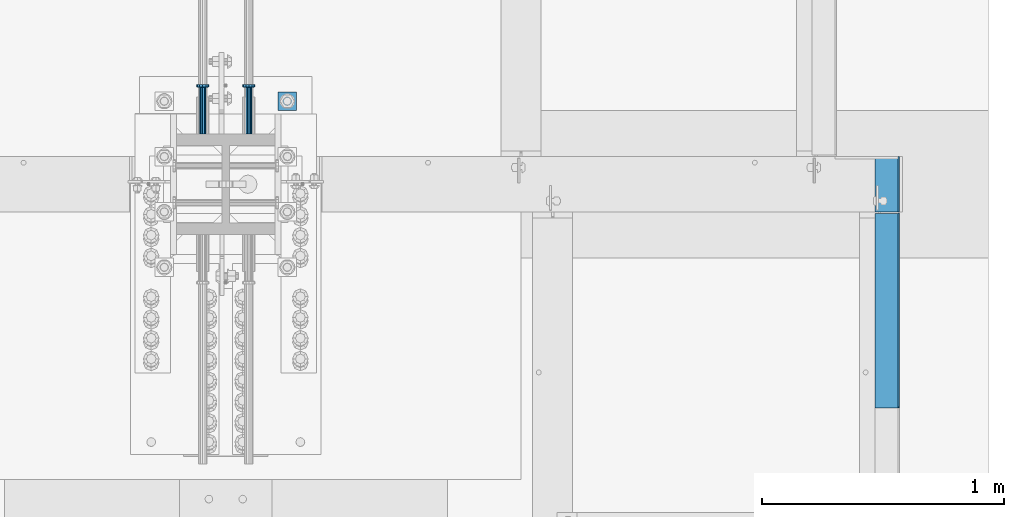
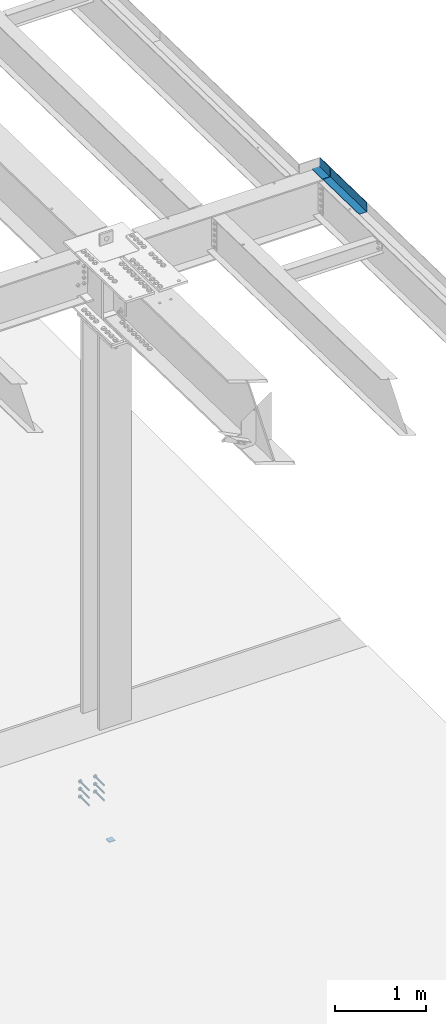
# One storey, part 1324 of 1763: 9 beams, 4 elements without a shape of their own.
"""IFC2X3 building model written with IfcOpenShell, lengths in millimetres."""

from ifc_helpers import new_model, si_unit, frame, origin_with_axes, place, context, subcontext, project, spatial, faceted_brep, material, type_object, element, aggregate, save


model = new_model("IFC2X3")

# Units and contexts
model_context = context("Model", 3, precision=1e-05, world=origin_with_axes())
body_context = subcontext(model_context, "Body", "Model", "MODEL_VIEW")
ifc_project = project(units=[si_unit("LENGTHUNIT", "METRE", prefix="MILLI"), si_unit("AREAUNIT", "SQUARE_METRE"), si_unit("VOLUMEUNIT", "CUBIC_METRE"), si_unit("MASSUNIT", "GRAM", prefix="KILO"), si_unit("TIMEUNIT", "SECOND"), si_unit("PLANEANGLEUNIT", "RADIAN"), si_unit("SOLIDANGLEUNIT", "STERADIAN"), si_unit("THERMODYNAMICTEMPERATUREUNIT", "DEGREE_CELSIUS"), si_unit("LUMINOUSINTENSITYUNIT", "LUMEN")], contexts=[model_context])

# Site, building, storey
site_placement = place(None, origin_with_axes())
site = spatial("IfcSite", under=ifc_project, at=site_placement, CompositionType="ELEMENT")
building_placement = place(site_placement, origin_with_axes())
building = spatial("IfcBuilding", under=site, at=building_placement, Name="Undefined", CompositionType="ELEMENT")
storey_placement = place(building_placement, origin_with_axes())
storey = spatial("IfcBuildingStorey", under=building, at=storey_placement, Name="Undefined", CompositionType="ELEMENT", Elevation=0.0)

# Assembly, beam
assembly_1_placement = place(storey_placement, origin_with_axes())
assembly_1 = element("IfcElementAssembly", 1, at=assembly_1_placement, inside=storey, Name="BEAM", AssemblyPlace="NOTDEFINED", PredefinedType="RIGID_FRAME")
ifc_material_1 = material(Name="STEEL/A36")
beam_type_1 = type_object("IfcBeamType", PredefinedType="NOTDEFINED")
beam_1_placement = place(assembly_1_placement, frame((-21348.1419611974, 13690.599999996, 11634.9147294638), z_axis=(0.0, -1.0, 0.0), x_axis=(1.0, 0.0, 0.0)))
beam_1 = element("IfcBeam", 2, at=beam_1_placement, type_object=beam_type_1, material=ifc_material_1, Name="BENT_PLATE", context=body_context, shape_type="Brep", body=[
    faceted_brep([(0.0, -3.17499999999927, -114.300000000003), (0.0, -3.17499999999927, 114.300000000003), (0.0, 3.17499999999927, 114.300000000003), (0.0, 3.17499999999927, -114.300000000003), (95.2499984741225, 3.17499999999927, 114.299999999999), (95.2499984741225, 3.17499999999927, -114.299999999999), (101.599998474121, -3.17499999999927, -114.299999999999), (101.599998474121, -3.17499999999927, 114.299999999999), (95.2499984741225, 123.825000000001, 114.299999999999), (95.2499984741225, 123.825000000001, -114.299999999999), (101.599998474121, 123.825000000001, 114.299999999999), (101.599998474121, 123.825000000001, -114.299999999999)], [[[0, 1, 2, 3]], [[3, 2, 4, 5]], [[1, 0, 6, 7]], [[5, 4, 8, 9]], [[4, 2, 1, 7, 10, 8]], [[7, 6, 11, 10]], [[6, 0, 3, 5, 9, 11]], [[10, 11, 9, 8]]]),
])
aggregate(assembly_1, [beam_1])

assembly_2_placement = place(storey_placement, origin_with_axes())
assembly_2 = element("IfcElementAssembly", 3, at=assembly_2_placement, inside=storey, Name="BEAM", AssemblyPlace="NOTDEFINED", PredefinedType="RIGID_FRAME")
beam_2_placement = place(assembly_2_placement, frame((-21348.1372736983, 13168.1616586829, 11645.8374789734), z_axis=(0.0, -0.999781542838788, 0.0209013539966307), x_axis=(1.0, 0.0, 0.0)))
beam_2 = element("IfcBeam", 4, at=beam_2_placement, type_object=beam_type_1, material=ifc_material_1, Name="BENT_PLATE", context=body_context, shape_type="Brep", body=[
    faceted_brep([(3.63797880709171e-12, -3.17500000013388, -401.010500000322), (-3.63797880709171e-12, -3.17499999986831, 401.010500000324), (-3.63797880709171e-12, 3.17500000013752, 401.01050000032), (3.63797880709171e-12, 3.17499999987194, -401.010500000324), (95.2499984741116, 3.17500000011933, 401.01050000032), (95.2499984741262, 3.17499999985557, -401.010500000322), (101.599998474125, -3.17500000015207, -401.01050000032), (101.59999847411, -3.1749999998865, 401.010500000324), (95.2499984741189, 123.825003583939, 401.010500000282), (95.2499984741189, 123.825003583685, -401.010500000362), (101.599998474117, 123.825003583939, 401.010500000282), (101.599998474117, 123.825003583685, -401.010500000362)], [[[0, 1, 2, 3]], [[3, 2, 4, 5]], [[1, 0, 6, 7]], [[5, 4, 8, 9]], [[4, 2, 1, 7, 10, 8]], [[7, 6, 11, 10]], [[6, 0, 3, 5, 9, 11]], [[10, 11, 9, 8]]]),
])
aggregate(assembly_2, [beam_2])

assembly_3_placement = place(storey_placement, origin_with_axes())
assembly_3 = element("IfcElementAssembly", 5, at=assembly_3_placement, inside=storey, Name="TEMPLATE", AssemblyPlace="NOTDEFINED", PredefinedType="RIGID_FRAME")
beam_type_2 = type_object("IfcBeamType", PredefinedType="NOTDEFINED")
beam_3_placement = place(assembly_3_placement, frame((-23773.8372736984, 13995.3999999999, 3348.0375), z_axis=(1.0, 0.0, 0.0), x_axis=(0.0, 1.0, 0.0)))
beam_3 = element("IfcBeam", 6, at=beam_3_placement, type_object=beam_type_2, material=ifc_material_1, Name="WASHER PLATE", context=body_context, shape_type="Brep", body=[
    faceted_brep([(0.0, 4.76249999999709, -38.1000000000004), (0.0, 4.76249999999709, 38.1000000000004), (76.2000000000007, 4.76249999999982, 38.0999999999985), (76.2000000000007, 4.76249999999982, -38.0999999999985), (0.0, -4.76249999999709, 38.1000000000004), (76.2000000000007, -4.76249999999982, 38.0999999999985), (0.0, -4.76249999999709, -38.1000000000004), (76.2000000000007, -4.76249999999982, -38.0999999999985)], [[[0, 1, 2, 3]], [[1, 4, 5, 2]], [[4, 6, 7, 5]], [[6, 0, 3, 7]], [[5, 7, 3, 2]], [[6, 4, 1, 0]]]),
])
aggregate(assembly_3, [beam_3])

# Assembly, beams
assembly_4_placement = place(storey_placement, origin_with_axes())
assembly_4 = element("IfcElementAssembly", 7, at=assembly_4_placement, inside=storey, Name="COLUMN", AssemblyPlace="NOTDEFINED", PredefinedType="RIGID_FRAME")
ifc_material_2 = material(Name="STEEL/A108")
beam_type_3 = type_object("IfcBeamType", PredefinedType="NOTDEFINED")
beam_4_placement = place(assembly_4_placement, frame((-23932.5872736985, 13898.5624312644, 4216.40000000002), z_axis=(1.0, 0.0, 0.0), x_axis=(0.0, 1.0, 0.0)))
beam_4 = element("IfcBeam", 8, at=beam_4_placement, type_object=beam_type_3, material=ifc_material_2, Name="HEADED STUD ANCHOR", context=body_context, shape_type="Brep", body=[
    faceted_brep([(0.0, -12.6999999999971, -1.81898940354586e-12), (3.63797880709171e-12, -11.0, -6.34999990463257), (191.00799999576, -11.0, -6.34999990454889), (191.007999995752, -12.6999998092651, 8.36735125631094e-11), (7.27595761418343e-12, -6.34999990463257, -11.0), (191.00799999576, -6.34999990463257, -10.9999999999163), (3.63797880709171e-12, 0.0, -12.6999998092651), (191.00799999576, 0.0, -12.6999998091815), (7.27595761418343e-12, 6.34999990463257, -11.0), (191.00799999576, 6.34999990463257, -10.9999999999163), (3.63797880709171e-12, 11.0, -6.34999990463257), (191.00799999576, 11.0, -6.34999990454889), (0.0, 12.6999999999971, -1.81898940354586e-12), (191.007999995752, 12.6999998092651, 8.36735125631094e-11), (0.0, 11.0, 6.34999990463257), (191.007999995752, 11.0, 6.34999990471624), (-3.63797880709171e-12, 6.34999990463257, 11.0), (191.007999995749, 6.34999990463257, 11.0000000000837), (-3.63797880709171e-12, 0.0, 12.6999998092651), (191.007999995749, 0.0, 12.6999998093488), (-3.63797880709171e-12, -6.34999990463257, 11.0), (191.007999995749, -6.34999990463257, 11.0000000000837), (0.0, -11.0, 6.34999990463257), (191.007999995752, -11.0, 6.34999990471624), (193.039999995715, -22.0, -12.6999998091796), (193.039999995708, -25.3999996185303, 8.54925019666553e-11), (193.039999995719, -12.6999998092651, -21.9999999999145), (193.039999995719, 0.0, -25.3999996184448), (193.039999995719, 12.6999998092651, -21.9999999999145), (193.039999995715, 22.0, -12.6999998091796), (193.039999995708, 25.3999996185303, 8.54925019666553e-11), (193.039999995704, 22.0, 12.6999998093506), (193.039999995701, 12.6999998092651, 22.0000000000855), (193.039999995697, 0.0, 25.3999996186158), (193.039999995701, -12.6999998092651, 22.0000000000855), (193.039999995704, -22.0, 12.6999998093506), (203.199999995486, -22.0, -12.6999998091742), (203.199999995482, -25.3999996185303, 9.09494701772928e-11), (203.199999995493, -12.6999998092651, -21.9999999999091), (203.199999995493, 0.0, -25.3999996184393), (203.199999995493, 12.6999998092651, -21.9999999999091), (203.199999995486, 22.0, -12.6999998091742), (203.199999995482, 25.3999996185303, 9.09494701772928e-11), (203.199999995479, 22.0, 12.6999998093561), (203.199999995475, 12.6999998092651, 22.0000000000909), (203.199999995471, 0.0, 25.3999996186212), (203.199999995475, -12.6999998092651, 22.0000000000909), (203.199999995479, -22.0, 12.6999998093561)], [[[0, 1, 2, 3]], [[1, 4, 5, 2]], [[4, 6, 7, 5]], [[6, 8, 9, 7]], [[8, 10, 11, 9]], [[10, 12, 13, 11]], [[12, 14, 15, 13]], [[14, 16, 17, 15]], [[16, 18, 19, 17]], [[18, 20, 21, 19]], [[20, 22, 23, 21]], [[22, 0, 3, 23]], [[22, 20, 18, 16, 14, 12, 10, 8, 6, 4, 1, 0]], [[3, 2, 24, 25]], [[2, 5, 26, 24]], [[5, 7, 27, 26]], [[7, 9, 28, 27]], [[9, 11, 29, 28]], [[11, 13, 30, 29]], [[13, 15, 31, 30]], [[15, 17, 32, 31]], [[17, 19, 33, 32]], [[19, 21, 34, 33]], [[21, 23, 35, 34]], [[23, 3, 25, 35]], [[25, 24, 36, 37]], [[24, 26, 38, 36]], [[26, 27, 39, 38]], [[27, 28, 40, 39]], [[28, 29, 41, 40]], [[29, 30, 42, 41]], [[30, 31, 43, 42]], [[31, 32, 44, 43]], [[32, 33, 45, 44]], [[33, 34, 46, 45]], [[34, 35, 47, 46]], [[35, 25, 37, 47]], [[38, 39, 40, 41, 42, 43, 44, 45, 46, 47, 37, 36]]]),
])
beam_5_placement = place(assembly_4_placement, frame((-23932.5872736985, 13898.5624312644, 4114.80000000002), z_axis=(1.0, 0.0, 0.0), x_axis=(0.0, 1.0, 0.0)))
beam_5 = element("IfcBeam", 9, at=beam_5_placement, type_object=beam_type_3, material=ifc_material_2, Name="HEADED STUD ANCHOR", context=body_context, shape_type="Brep", body=[
    faceted_brep([(0.0, -12.6999999999971, -1.81898940354586e-12), (3.63797880709171e-12, -11.0, -6.34999990463257), (191.00799999576, -11.0, -6.34999990454889), (191.007999995752, -12.6999998092651, 8.36735125631094e-11), (7.27595761418343e-12, -6.34999990463257, -11.0), (191.00799999576, -6.34999990463257, -10.9999999999163), (3.63797880709171e-12, 0.0, -12.6999998092651), (191.00799999576, 0.0, -12.6999998091815), (7.27595761418343e-12, 6.34999990463257, -11.0), (191.00799999576, 6.34999990463257, -10.9999999999163), (3.63797880709171e-12, 11.0, -6.34999990463257), (191.00799999576, 11.0, -6.34999990454889), (0.0, 12.6999999999971, -1.81898940354586e-12), (191.007999995752, 12.6999998092651, 8.36735125631094e-11), (0.0, 11.0, 6.34999990463257), (191.007999995752, 11.0, 6.34999990471624), (-3.63797880709171e-12, 6.34999990463257, 11.0), (191.007999995749, 6.34999990463257, 11.0000000000837), (-3.63797880709171e-12, 0.0, 12.6999998092651), (191.007999995749, 0.0, 12.6999998093488), (-3.63797880709171e-12, -6.34999990463257, 11.0), (191.007999995749, -6.34999990463257, 11.0000000000837), (0.0, -11.0, 6.34999990463257), (191.007999995752, -11.0, 6.34999990471624), (193.039999995715, -22.0, -12.6999998091796), (193.039999995708, -25.3999996185303, 8.54925019666553e-11), (193.039999995719, -12.6999998092651, -21.9999999999145), (193.039999995719, 0.0, -25.3999996184448), (193.039999995719, 12.6999998092651, -21.9999999999145), (193.039999995715, 22.0, -12.6999998091796), (193.039999995708, 25.3999996185303, 8.54925019666553e-11), (193.039999995704, 22.0, 12.6999998093506), (193.039999995701, 12.6999998092651, 22.0000000000855), (193.039999995697, 0.0, 25.3999996186158), (193.039999995701, -12.6999998092651, 22.0000000000855), (193.039999995704, -22.0, 12.6999998093506), (203.199999995486, -22.0, -12.6999998091742), (203.199999995482, -25.3999996185303, 9.09494701772928e-11), (203.199999995493, -12.6999998092651, -21.9999999999091), (203.199999995493, 0.0, -25.3999996184393), (203.199999995493, 12.6999998092651, -21.9999999999091), (203.199999995486, 22.0, -12.6999998091742), (203.199999995482, 25.3999996185303, 9.09494701772928e-11), (203.199999995479, 22.0, 12.6999998093561), (203.199999995475, 12.6999998092651, 22.0000000000909), (203.199999995471, 0.0, 25.3999996186212), (203.199999995475, -12.6999998092651, 22.0000000000909), (203.199999995479, -22.0, 12.6999998093561)], [[[0, 1, 2, 3]], [[1, 4, 5, 2]], [[4, 6, 7, 5]], [[6, 8, 9, 7]], [[8, 10, 11, 9]], [[10, 12, 13, 11]], [[12, 14, 15, 13]], [[14, 16, 17, 15]], [[16, 18, 19, 17]], [[18, 20, 21, 19]], [[20, 22, 23, 21]], [[22, 0, 3, 23]], [[22, 20, 18, 16, 14, 12, 10, 8, 6, 4, 1, 0]], [[3, 2, 24, 25]], [[2, 5, 26, 24]], [[5, 7, 27, 26]], [[7, 9, 28, 27]], [[9, 11, 29, 28]], [[11, 13, 30, 29]], [[13, 15, 31, 30]], [[15, 17, 32, 31]], [[17, 19, 33, 32]], [[19, 21, 34, 33]], [[21, 23, 35, 34]], [[23, 3, 25, 35]], [[25, 24, 36, 37]], [[24, 26, 38, 36]], [[26, 27, 39, 38]], [[27, 28, 40, 39]], [[28, 29, 41, 40]], [[29, 30, 42, 41]], [[30, 31, 43, 42]], [[31, 32, 44, 43]], [[32, 33, 45, 44]], [[33, 34, 46, 45]], [[34, 35, 47, 46]], [[35, 25, 37, 47]], [[38, 39, 40, 41, 42, 43, 44, 45, 46, 47, 37, 36]]]),
])
beam_6_placement = place(assembly_4_placement, frame((-24123.0872736984, 13898.5625, 4216.40000000002), z_axis=(1.0, 0.0, 0.0), x_axis=(0.0, 1.0, 0.0)))
beam_6 = element("IfcBeam", 10, at=beam_6_placement, type_object=beam_type_3, material=ifc_material_2, Name="HEADED STUD ANCHOR", context=body_context, shape_type="Brep", body=[
    faceted_brep([(0.0, -12.6999999999971, -1.81898940354586e-12), (3.63797880709171e-12, -11.0, -6.34999990463257), (191.00799999576, -11.0, -6.34999990454889), (191.007999995752, -12.6999998092651, 8.36735125631094e-11), (7.27595761418343e-12, -6.34999990463257, -11.0), (191.00799999576, -6.34999990463257, -10.9999999999163), (3.63797880709171e-12, 0.0, -12.6999998092651), (191.00799999576, 0.0, -12.6999998091815), (7.27595761418343e-12, 6.34999990463257, -11.0), (191.00799999576, 6.34999990463257, -10.9999999999163), (3.63797880709171e-12, 11.0, -6.34999990463257), (191.00799999576, 11.0, -6.34999990454889), (0.0, 12.6999999999971, -1.81898940354586e-12), (191.007999995752, 12.6999998092651, 8.36735125631094e-11), (0.0, 11.0, 6.34999990463257), (191.007999995752, 11.0, 6.34999990471624), (-3.63797880709171e-12, 6.34999990463257, 11.0), (191.007999995749, 6.34999990463257, 11.0000000000837), (-3.63797880709171e-12, 0.0, 12.6999998092651), (191.007999995749, 0.0, 12.6999998093488), (-3.63797880709171e-12, -6.34999990463257, 11.0), (191.007999995749, -6.34999990463257, 11.0000000000837), (0.0, -11.0, 6.34999990463257), (191.007999995752, -11.0, 6.34999990471624), (193.039999995715, -22.0, -12.6999998091796), (193.039999995708, -25.3999996185303, 8.54925019666553e-11), (193.039999995719, -12.6999998092651, -21.9999999999145), (193.039999995719, 0.0, -25.3999996184448), (193.039999995719, 12.6999998092651, -21.9999999999145), (193.039999995715, 22.0, -12.6999998091796), (193.039999995708, 25.3999996185303, 8.54925019666553e-11), (193.039999995704, 22.0, 12.6999998093506), (193.039999995701, 12.6999998092651, 22.0000000000855), (193.039999995697, 0.0, 25.3999996186158), (193.039999995701, -12.6999998092651, 22.0000000000855), (193.039999995704, -22.0, 12.6999998093506), (203.199999995486, -22.0, -12.6999998091742), (203.199999995482, -25.3999996185303, 9.09494701772928e-11), (203.199999995493, -12.6999998092651, -21.9999999999091), (203.199999995493, 0.0, -25.3999996184393), (203.199999995493, 12.6999998092651, -21.9999999999091), (203.199999995486, 22.0, -12.6999998091742), (203.199999995482, 25.3999996185303, 9.09494701772928e-11), (203.199999995479, 22.0, 12.6999998093561), (203.199999995475, 12.6999998092651, 22.0000000000909), (203.199999995471, 0.0, 25.3999996186212), (203.199999995475, -12.6999998092651, 22.0000000000909), (203.199999995479, -22.0, 12.6999998093561)], [[[0, 1, 2, 3]], [[1, 4, 5, 2]], [[4, 6, 7, 5]], [[6, 8, 9, 7]], [[8, 10, 11, 9]], [[10, 12, 13, 11]], [[12, 14, 15, 13]], [[14, 16, 17, 15]], [[16, 18, 19, 17]], [[18, 20, 21, 19]], [[20, 22, 23, 21]], [[22, 0, 3, 23]], [[22, 20, 18, 16, 14, 12, 10, 8, 6, 4, 1, 0]], [[3, 2, 24, 25]], [[2, 5, 26, 24]], [[5, 7, 27, 26]], [[7, 9, 28, 27]], [[9, 11, 29, 28]], [[11, 13, 30, 29]], [[13, 15, 31, 30]], [[15, 17, 32, 31]], [[17, 19, 33, 32]], [[19, 21, 34, 33]], [[21, 23, 35, 34]], [[23, 3, 25, 35]], [[25, 24, 36, 37]], [[24, 26, 38, 36]], [[26, 27, 39, 38]], [[27, 28, 40, 39]], [[28, 29, 41, 40]], [[29, 30, 42, 41]], [[30, 31, 43, 42]], [[31, 32, 44, 43]], [[32, 33, 45, 44]], [[33, 34, 46, 45]], [[34, 35, 47, 46]], [[35, 25, 37, 47]], [[38, 39, 40, 41, 42, 43, 44, 45, 46, 47, 37, 36]]]),
])
beam_7_placement = place(assembly_4_placement, frame((-24123.0872736984, 13898.5625, 4114.80000000002), z_axis=(1.0, 0.0, 0.0), x_axis=(0.0, 1.0, 0.0)))
beam_7 = element("IfcBeam", 11, at=beam_7_placement, type_object=beam_type_3, material=ifc_material_2, Name="HEADED STUD ANCHOR", context=body_context, shape_type="Brep", body=[
    faceted_brep([(0.0, -12.6999999999971, -1.81898940354586e-12), (3.63797880709171e-12, -11.0, -6.34999990463257), (191.00799999576, -11.0, -6.34999990454889), (191.007999995752, -12.6999998092651, 8.36735125631094e-11), (7.27595761418343e-12, -6.34999990463257, -11.0), (191.00799999576, -6.34999990463257, -10.9999999999163), (3.63797880709171e-12, 0.0, -12.6999998092651), (191.00799999576, 0.0, -12.6999998091815), (7.27595761418343e-12, 6.34999990463257, -11.0), (191.00799999576, 6.34999990463257, -10.9999999999163), (3.63797880709171e-12, 11.0, -6.34999990463257), (191.00799999576, 11.0, -6.34999990454889), (0.0, 12.6999999999971, -1.81898940354586e-12), (191.007999995752, 12.6999998092651, 8.36735125631094e-11), (0.0, 11.0, 6.34999990463257), (191.007999995752, 11.0, 6.34999990471624), (-3.63797880709171e-12, 6.34999990463257, 11.0), (191.007999995749, 6.34999990463257, 11.0000000000837), (-3.63797880709171e-12, 0.0, 12.6999998092651), (191.007999995749, 0.0, 12.6999998093488), (-3.63797880709171e-12, -6.34999990463257, 11.0), (191.007999995749, -6.34999990463257, 11.0000000000837), (0.0, -11.0, 6.34999990463257), (191.007999995752, -11.0, 6.34999990471624), (193.039999995715, -22.0, -12.6999998091796), (193.039999995708, -25.3999996185303, 8.54925019666553e-11), (193.039999995719, -12.6999998092651, -21.9999999999145), (193.039999995719, 0.0, -25.3999996184448), (193.039999995719, 12.6999998092651, -21.9999999999145), (193.039999995715, 22.0, -12.6999998091796), (193.039999995708, 25.3999996185303, 8.54925019666553e-11), (193.039999995704, 22.0, 12.6999998093506), (193.039999995701, 12.6999998092651, 22.0000000000855), (193.039999995697, 0.0, 25.3999996186158), (193.039999995701, -12.6999998092651, 22.0000000000855), (193.039999995704, -22.0, 12.6999998093506), (203.199999995486, -22.0, -12.6999998091742), (203.199999995482, -25.3999996185303, 9.09494701772928e-11), (203.199999995493, -12.6999998092651, -21.9999999999091), (203.199999995493, 0.0, -25.3999996184393), (203.199999995493, 12.6999998092651, -21.9999999999091), (203.199999995486, 22.0, -12.6999998091742), (203.199999995482, 25.3999996185303, 9.09494701772928e-11), (203.199999995479, 22.0, 12.6999998093561), (203.199999995475, 12.6999998092651, 22.0000000000909), (203.199999995471, 0.0, 25.3999996186212), (203.199999995475, -12.6999998092651, 22.0000000000909), (203.199999995479, -22.0, 12.6999998093561)], [[[0, 1, 2, 3]], [[1, 4, 5, 2]], [[4, 6, 7, 5]], [[6, 8, 9, 7]], [[8, 10, 11, 9]], [[10, 12, 13, 11]], [[12, 14, 15, 13]], [[14, 16, 17, 15]], [[16, 18, 19, 17]], [[18, 20, 21, 19]], [[20, 22, 23, 21]], [[22, 0, 3, 23]], [[22, 20, 18, 16, 14, 12, 10, 8, 6, 4, 1, 0]], [[3, 2, 24, 25]], [[2, 5, 26, 24]], [[5, 7, 27, 26]], [[7, 9, 28, 27]], [[9, 11, 29, 28]], [[11, 13, 30, 29]], [[13, 15, 31, 30]], [[15, 17, 32, 31]], [[17, 19, 33, 32]], [[19, 21, 34, 33]], [[21, 23, 35, 34]], [[23, 3, 25, 35]], [[25, 24, 36, 37]], [[24, 26, 38, 36]], [[26, 27, 39, 38]], [[27, 28, 40, 39]], [[28, 29, 41, 40]], [[29, 30, 42, 41]], [[30, 31, 43, 42]], [[31, 32, 44, 43]], [[32, 33, 45, 44]], [[33, 34, 46, 45]], [[34, 35, 47, 46]], [[35, 25, 37, 47]], [[38, 39, 40, 41, 42, 43, 44, 45, 46, 47, 37, 36]]]),
])
beam_8_placement = place(assembly_4_placement, frame((-24123.0872736984, 13898.562431265, 4013.2), z_axis=(1.0, 0.0, 0.0), x_axis=(0.0, 1.0, 0.0)))
beam_8 = element("IfcBeam", 12, at=beam_8_placement, type_object=beam_type_3, material=ifc_material_2, Name="HEADED STUD ANCHOR", context=body_context, shape_type="Brep", body=[
    faceted_brep([(0.0, -12.6999999999971, -1.81898940354586e-12), (3.63797880709171e-12, -11.0, -6.34999990463257), (191.00799999576, -11.0, -6.34999990454889), (191.007999995752, -12.6999998092651, 8.36735125631094e-11), (7.27595761418343e-12, -6.34999990463257, -11.0), (191.00799999576, -6.34999990463257, -10.9999999999163), (3.63797880709171e-12, 0.0, -12.6999998092651), (191.00799999576, 0.0, -12.6999998091815), (7.27595761418343e-12, 6.34999990463257, -11.0), (191.00799999576, 6.34999990463257, -10.9999999999163), (3.63797880709171e-12, 11.0, -6.34999990463257), (191.00799999576, 11.0, -6.34999990454889), (0.0, 12.6999999999971, -1.81898940354586e-12), (191.007999995752, 12.6999998092651, 8.36735125631094e-11), (0.0, 11.0, 6.34999990463257), (191.007999995752, 11.0, 6.34999990471624), (-3.63797880709171e-12, 6.34999990463257, 11.0), (191.007999995749, 6.34999990463257, 11.0000000000837), (-3.63797880709171e-12, 0.0, 12.6999998092651), (191.007999995749, 0.0, 12.6999998093488), (-3.63797880709171e-12, -6.34999990463257, 11.0), (191.007999995749, -6.34999990463257, 11.0000000000837), (0.0, -11.0, 6.34999990463257), (191.007999995752, -11.0, 6.34999990471624), (193.039999995715, -22.0, -12.6999998091796), (193.039999995708, -25.3999996185303, 8.54925019666553e-11), (193.039999995719, -12.6999998092651, -21.9999999999145), (193.039999995719, 0.0, -25.3999996184448), (193.039999995719, 12.6999998092651, -21.9999999999145), (193.039999995715, 22.0, -12.6999998091796), (193.039999995708, 25.3999996185303, 8.54925019666553e-11), (193.039999995704, 22.0, 12.6999998093506), (193.039999995701, 12.6999998092651, 22.0000000000855), (193.039999995697, 0.0, 25.3999996186158), (193.039999995701, -12.6999998092651, 22.0000000000855), (193.039999995704, -22.0, 12.6999998093506), (203.199999995486, -22.0, -12.6999998091742), (203.199999995482, -25.3999996185303, 9.09494701772928e-11), (203.199999995493, -12.6999998092651, -21.9999999999091), (203.199999995493, 0.0, -25.3999996184393), (203.199999995493, 12.6999998092651, -21.9999999999091), (203.199999995486, 22.0, -12.6999998091742), (203.199999995482, 25.3999996185303, 9.09494701772928e-11), (203.199999995479, 22.0, 12.6999998093561), (203.199999995475, 12.6999998092651, 22.0000000000909), (203.199999995471, 0.0, 25.3999996186212), (203.199999995475, -12.6999998092651, 22.0000000000909), (203.199999995479, -22.0, 12.6999998093561)], [[[0, 1, 2, 3]], [[1, 4, 5, 2]], [[4, 6, 7, 5]], [[6, 8, 9, 7]], [[8, 10, 11, 9]], [[10, 12, 13, 11]], [[12, 14, 15, 13]], [[14, 16, 17, 15]], [[16, 18, 19, 17]], [[18, 20, 21, 19]], [[20, 22, 23, 21]], [[22, 0, 3, 23]], [[22, 20, 18, 16, 14, 12, 10, 8, 6, 4, 1, 0]], [[3, 2, 24, 25]], [[2, 5, 26, 24]], [[5, 7, 27, 26]], [[7, 9, 28, 27]], [[9, 11, 29, 28]], [[11, 13, 30, 29]], [[13, 15, 31, 30]], [[15, 17, 32, 31]], [[17, 19, 33, 32]], [[19, 21, 34, 33]], [[21, 23, 35, 34]], [[23, 3, 25, 35]], [[25, 24, 36, 37]], [[24, 26, 38, 36]], [[26, 27, 39, 38]], [[27, 28, 40, 39]], [[28, 29, 41, 40]], [[29, 30, 42, 41]], [[30, 31, 43, 42]], [[31, 32, 44, 43]], [[32, 33, 45, 44]], [[33, 34, 46, 45]], [[34, 35, 47, 46]], [[35, 25, 37, 47]], [[38, 39, 40, 41, 42, 43, 44, 45, 46, 47, 37, 36]]]),
])
beam_9_placement = place(assembly_4_placement, frame((-23932.5872736985, 13898.5623625295, 4013.2), z_axis=(1.0, 0.0, 0.0), x_axis=(0.0, 1.0, 0.0)))
beam_9 = element("IfcBeam", 13, at=beam_9_placement, type_object=beam_type_3, material=ifc_material_2, Name="HEADED STUD ANCHOR", context=body_context, shape_type="Brep", body=[
    faceted_brep([(0.0, -12.6999999999971, -1.81898940354586e-12), (3.63797880709171e-12, -11.0, -6.34999990463257), (191.00799999576, -11.0, -6.34999990454889), (191.007999995752, -12.6999998092651, 8.36735125631094e-11), (7.27595761418343e-12, -6.34999990463257, -11.0), (191.00799999576, -6.34999990463257, -10.9999999999163), (3.63797880709171e-12, 0.0, -12.6999998092651), (191.00799999576, 0.0, -12.6999998091815), (7.27595761418343e-12, 6.34999990463257, -11.0), (191.00799999576, 6.34999990463257, -10.9999999999163), (3.63797880709171e-12, 11.0, -6.34999990463257), (191.00799999576, 11.0, -6.34999990454889), (0.0, 12.6999999999971, -1.81898940354586e-12), (191.007999995752, 12.6999998092651, 8.36735125631094e-11), (0.0, 11.0, 6.34999990463257), (191.007999995752, 11.0, 6.34999990471624), (-3.63797880709171e-12, 6.34999990463257, 11.0), (191.007999995749, 6.34999990463257, 11.0000000000837), (-3.63797880709171e-12, 0.0, 12.6999998092651), (191.007999995749, 0.0, 12.6999998093488), (-3.63797880709171e-12, -6.34999990463257, 11.0), (191.007999995749, -6.34999990463257, 11.0000000000837), (0.0, -11.0, 6.34999990463257), (191.007999995752, -11.0, 6.34999990471624), (193.039999995715, -22.0, -12.6999998091796), (193.039999995708, -25.3999996185303, 8.54925019666553e-11), (193.039999995719, -12.6999998092651, -21.9999999999145), (193.039999995719, 0.0, -25.3999996184448), (193.039999995719, 12.6999998092651, -21.9999999999145), (193.039999995715, 22.0, -12.6999998091796), (193.039999995708, 25.3999996185303, 8.54925019666553e-11), (193.039999995704, 22.0, 12.6999998093506), (193.039999995701, 12.6999998092651, 22.0000000000855), (193.039999995697, 0.0, 25.3999996186158), (193.039999995701, -12.6999998092651, 22.0000000000855), (193.039999995704, -22.0, 12.6999998093506), (203.199999995486, -22.0, -12.6999998091742), (203.199999995482, -25.3999996185303, 9.09494701772928e-11), (203.199999995493, -12.6999998092651, -21.9999999999091), (203.199999995493, 0.0, -25.3999996184393), (203.199999995493, 12.6999998092651, -21.9999999999091), (203.199999995486, 22.0, -12.6999998091742), (203.199999995482, 25.3999996185303, 9.09494701772928e-11), (203.199999995479, 22.0, 12.6999998093561), (203.199999995475, 12.6999998092651, 22.0000000000909), (203.199999995471, 0.0, 25.3999996186212), (203.199999995475, -12.6999998092651, 22.0000000000909), (203.199999995479, -22.0, 12.6999998093561)], [[[0, 1, 2, 3]], [[1, 4, 5, 2]], [[4, 6, 7, 5]], [[6, 8, 9, 7]], [[8, 10, 11, 9]], [[10, 12, 13, 11]], [[12, 14, 15, 13]], [[14, 16, 17, 15]], [[16, 18, 19, 17]], [[18, 20, 21, 19]], [[20, 22, 23, 21]], [[22, 0, 3, 23]], [[22, 20, 18, 16, 14, 12, 10, 8, 6, 4, 1, 0]], [[3, 2, 24, 25]], [[2, 5, 26, 24]], [[5, 7, 27, 26]], [[7, 9, 28, 27]], [[9, 11, 29, 28]], [[11, 13, 30, 29]], [[13, 15, 31, 30]], [[15, 17, 32, 31]], [[17, 19, 33, 32]], [[19, 21, 34, 33]], [[21, 23, 35, 34]], [[23, 3, 25, 35]], [[25, 24, 36, 37]], [[24, 26, 38, 36]], [[26, 27, 39, 38]], [[27, 28, 40, 39]], [[28, 29, 41, 40]], [[29, 30, 42, 41]], [[30, 31, 43, 42]], [[31, 32, 44, 43]], [[32, 33, 45, 44]], [[33, 34, 46, 45]], [[34, 35, 47, 46]], [[35, 25, 37, 47]], [[38, 39, 40, 41, 42, 43, 44, 45, 46, 47, 37, 36]]]),
])
aggregate(assembly_4, [beam_4, beam_5, beam_6, beam_7, beam_8, beam_9])

save(model, "model.ifc")
